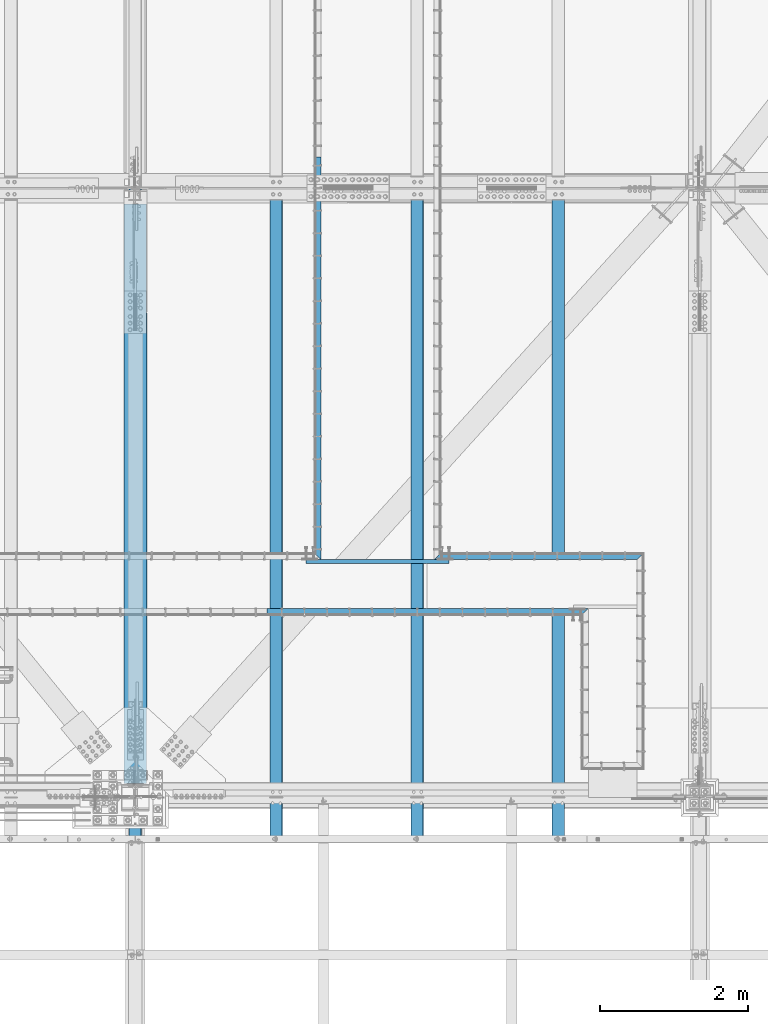
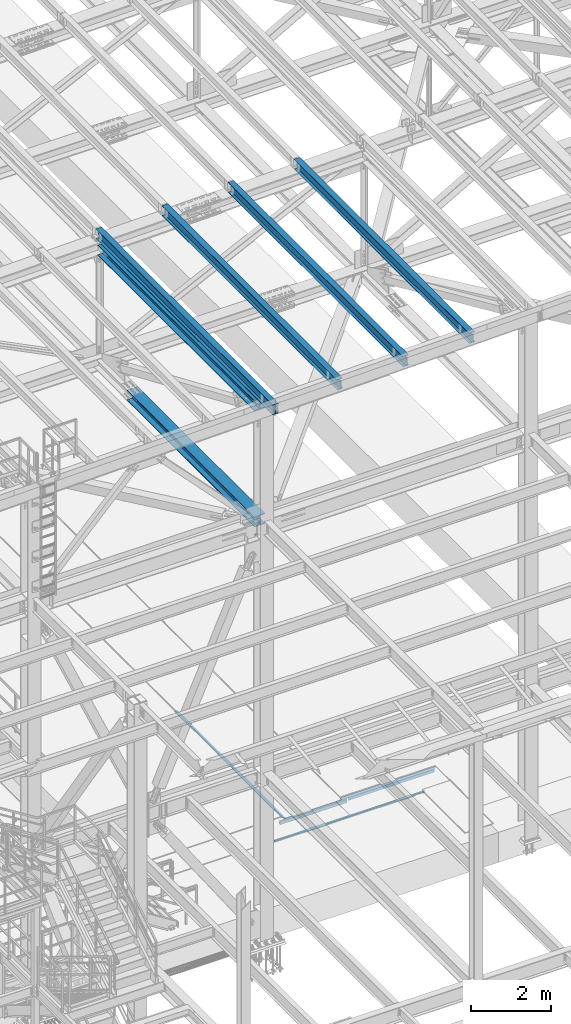
# One storey, part 1799 of 3843: 10 beams, 10 elements without a shape of their own.
"""IFC2X3 building model written with IfcOpenShell, lengths in millimetres."""

from ifc_helpers import new_model, si_unit, frame, origin_with_axes, place, context, subcontext, project, spatial, faceted_brep, material, type_object, element, aggregate, save


model = new_model("IFC2X3")

# Units and contexts
model_context = context("Model", 3, precision=1e-05, world=origin_with_axes())
body_context = subcontext(model_context, "Body", "Model", "MODEL_VIEW")
ifc_project = project(units=[si_unit("LENGTHUNIT", "METRE", prefix="MILLI"), si_unit("AREAUNIT", "SQUARE_METRE"), si_unit("VOLUMEUNIT", "CUBIC_METRE"), si_unit("MASSUNIT", "GRAM", prefix="KILO"), si_unit("TIMEUNIT", "SECOND"), si_unit("PLANEANGLEUNIT", "RADIAN"), si_unit("SOLIDANGLEUNIT", "STERADIAN"), si_unit("THERMODYNAMICTEMPERATUREUNIT", "DEGREE_CELSIUS"), si_unit("LUMINOUSINTENSITYUNIT", "LUMEN")], contexts=[model_context])

# Site, building, storey
site_placement = place(None, origin_with_axes())
site = spatial("IfcSite", under=ifc_project, at=site_placement, CompositionType="ELEMENT")
building_placement = place(site_placement, origin_with_axes())
building = spatial("IfcBuilding", under=site, at=building_placement, Name="Undefined", CompositionType="ELEMENT")
storey_placement = place(building_placement, origin_with_axes())
storey = spatial("IfcBuildingStorey", under=building, at=storey_placement, Name="Undefined", CompositionType="ELEMENT", Elevation=0.0)

# Assembly, beam
assembly_1_placement = place(storey_placement, origin_with_axes())
assembly_1 = element("IfcElementAssembly", 1, at=assembly_1_placement, inside=storey, Name="EMBED_ANGLE", AssemblyPlace="NOTDEFINED", PredefinedType="RIGID_FRAME")
ifc_material_1 = material(Name="STEEL/A36")
beam_type_1 = type_object("IfcBeamType", Name="L3-1/2X3-1/2X5/16", PredefinedType="NOTDEFINED")
beam_1_placement = place(assembly_1_placement, frame((66669.4119999985, 28873.45, 30410.15), z_axis=(0.0, 0.0, -1.0), x_axis=(1.0, 0.0, 0.0)))
beam_1 = element("IfcBeam", 2, at=beam_1_placement, type_object=beam_type_1, material=ifc_material_1, Name="EMBED_ANGLE", ObjectType="L3-1/2X3-1/2X5/16", context=body_context, shape_type="Brep", body=[
    faceted_brep([(44.4500000014959, 36.5125000000007, 44.4500000000007), (44.4499983150599, 36.5125000000007, -36.5125000001281), (44.4500000014959, 44.4500000000007, -36.5124999999935), (44.4500000014959, 44.4500000000007, 44.4500000000007), (260.349998315098, 36.5125000000007, -36.5125000007247), (260.350000001519, 44.4500000000007, -36.5124999999971), (260.349981232008, 36.5125000000007, 44.4499999992695), (260.350000001519, 44.4500000000007, 44.4500000000007), (2751.13746728744, 36.5125000000007, -36.5125000076368), (2751.13745121389, 36.5125000000007, 44.4500000000007), (260.349998315098, -44.4499999999971, -36.5125000007247), (88.9000039503298, -44.4500000001644, -36.5125000000007), (88.8999999971129, -44.4500000000007, -44.4499999999971), (2832.09995201537, -44.4500000000007, -44.4500000000007), (2832.09995201537, -44.4500000000007, -36.5125000000007), (44.4500000014959, 1.81898940354586e-11, -36.5125000000007), (7.93749960740388, 36.5125000000007, -36.5124999999825), (7.93750032749085, 36.5124999999825, 44.4500000000007), (-3.63797880709171e-12, 44.4499999999971, 44.4500000000007), (-3.63797880709171e-12, 44.4499999999971, -44.4500000000007), (2743.19996850427, 44.4500000000007, -44.4500000076223), (2743.19995113531, 44.4500000000007, 44.4500000000007)], [[[0, 1, 2, 3]], [[4, 5, 2, 1]], [[6, 7, 5, 4]], [[8, 9, 6, 4]], [[10, 11, 12, 13, 14]], [[12, 11, 15, 16, 17, 18, 19]], [[12, 19, 20, 13]], [[9, 8, 14, 13, 20, 21]], [[4, 1, 16, 15, 11, 10, 14, 8]], [[17, 16, 1, 0]], [[18, 17, 0, 3]], [[21, 20, 19, 18, 3, 2, 5, 7]], [[9, 21, 7, 6]]]),
])
aggregate(assembly_1, [beam_1])

assembly_2_placement = place(storey_placement, origin_with_axes())
assembly_2 = element("IfcElementAssembly", 3, at=assembly_2_placement, inside=storey, Name="EMBED_ANGLE", AssemblyPlace="NOTDEFINED", PredefinedType="RIGID_FRAME")
beam_2_placement = place(assembly_2_placement, frame((64415.1623417764, 28124.15, 30410.15), z_axis=(0.0, -1.0, 0.0), x_axis=(1.0, 0.0, 0.0)))
beam_2 = element("IfcBeam", 4, at=beam_2_placement, type_object=beam_type_1, material=ifc_material_1, Name="EMBED_ANGLE", ObjectType="L3-1/2X3-1/2X5/16", context=body_context, shape_type="Brep", body=[
    faceted_brep([(4076.69926759853, -44.4500000000007, -36.5125000000007), (4076.69926759853, -44.4500000000007, -44.4500000000007), (4076.69926759853, 36.5125000000007, -44.4500000000007), (4076.69926759853, 36.5125000000007, -36.5125000000007), (4292.59926759854, 36.5125000000007, -44.4500000000007), (4292.59926759854, 36.5125000000007, -36.5125000000007), (4292.59926759854, -44.4500000000007, -36.5125000000007), (4292.59926759854, -44.4500000000007, -44.4500000000007), (4337.04946592326, -44.4500000000007, -44.4500000000007), (4329.11196648452, -44.4500000000007, -36.5125000000007), (3.63797880709171e-12, -44.4499999999971, -44.4500000000007), (-3.63797880709171e-12, 44.4499999999971, -44.4500000000007), (4337.04946592326, 44.4500000000007, -44.4500000000007), (3.63797880709171e-12, -44.4499999999971, -36.5125000000007), (-3.63797880709171e-12, 36.5124999999971, -36.5125000000007), (-3.63797880709171e-12, 36.5124999999971, 44.4500000000007), (-3.63797880709171e-12, 44.4499999999971, 44.4500000000007), (4076.69926759853, 36.5125000000007, 44.4500000000007), (4248.14947220943, 36.5125000000007, 44.4500000000007), (4248.14947220943, 44.4500000000007, 44.4500000000007), (4292.59926759854, 36.5125000000007, 0.000201467813894851), (4329.11196648452, 36.5125000000007, -36.5125000000007)], [[[0, 1, 2, 3]], [[3, 2, 4, 5]], [[6, 5, 4, 7]], [[8, 9, 6, 7]], [[2, 1, 10, 11, 12, 8, 7, 4]], [[13, 10, 1, 0]], [[14, 13, 0, 3]], [[10, 13, 14, 15, 16, 11]], [[16, 15, 17, 18, 19]], [[11, 16, 19, 12]], [[18, 20, 21, 9, 8, 12, 19]], [[17, 15, 14, 3, 5, 21, 20, 18]], [[9, 21, 5, 6]]]),
])
aggregate(assembly_2, [beam_2])

assembly_3_placement = place(storey_placement, origin_with_axes())
assembly_3 = element("IfcElementAssembly", 5, at=assembly_3_placement, inside=storey, Name="EMBED_ANGLE", AssemblyPlace="NOTDEFINED", PredefinedType="RIGID_FRAME")
beam_3_placement = place(assembly_3_placement, frame((65101.0255556641, 28829.0, 30410.15), z_axis=(0.0, 0.0, -1.0), x_axis=(0.0, 1.0, 0.0)))
beam_3 = element("IfcBeam", 6, at=beam_3_placement, type_object=beam_type_1, material=ifc_material_1, Name="EMBED_ANGLE", ObjectType="L3-1/2X3-1/2X5/16", context=body_context, shape_type="Brep", body=[
    faceted_brep([(-3.63797880709171e-12, 44.4499999999971, -44.4500000000007), (-3.63797880709171e-12, 44.4499999999971, 44.4500000000007), (5435.6001953125, 44.4499999999971, 44.4500000000007), (5435.6001953125, 44.4499999999971, -44.4500000000007), (7.93750032749085, 36.5124999999825, 44.4500000000007), (5435.60019531249, 36.5124999999971, 44.4500000000007), (7.93749960740388, 36.5125000000007, -36.5124999999825), (5435.60019531249, 36.5124999999971, -36.5125000000007), (88.9000039503298, -44.4500000001644, -36.5125000000007), (5435.60019531249, -44.4499999999971, -36.5125000000007), (88.8999999971129, -44.4500000000007, -44.4499999999971), (5435.60019531249, -44.4499999999971, -44.4500000000007)], [[[0, 1, 2, 3]], [[1, 4, 5, 2]], [[4, 6, 7, 5]], [[6, 8, 9, 7]], [[8, 10, 11, 9]], [[10, 0, 3, 11]], [[5, 7, 9, 11, 3, 2]], [[10, 8, 6, 4, 1, 0]]]),
])
aggregate(assembly_3, [beam_3])

assembly_4_placement = place(storey_placement, origin_with_axes())
assembly_4 = element("IfcElementAssembly", 7, at=assembly_4_placement, inside=storey, Name="BEAM", AssemblyPlace="NOTDEFINED", PredefinedType="RIGID_FRAME")
ifc_material_2 = material(Name="STEEL/A992")
beam_type_2 = type_object("IfcBeamType", Name="W12X26", PredefinedType="NOTDEFINED")
beam_4_placement = place(assembly_4_placement, frame((62633.1092622695, 25006.0787452875, 46125.2705282097), z_axis=(-0.0211520984080489, -0.00142217399974833, 0.999775257822502), x_axis=(0.0, 0.999998988257743, 0.00142249200036651)))
beam_4 = element("IfcBeam", 8, at=beam_4_placement, type_object=beam_type_2, material=ifc_material_2, Name="BEAM", ObjectType="W12X26", context=body_context, shape_type="Brep", body=[
    faceted_brep([(0.0, 82.5500000000029, -155.574999999997), (0.0, 82.5500000000029, -146.050000000003), (8826.51999255239, 82.5500000000393, -146.049999990893), (8826.50644633373, 82.5500000000684, -155.574999990939), (0.0, 3.17500000000291, -146.050000000003), (8826.52238084464, 3.17500000018481, -146.049999990959), (0.0, 3.17500000000291, 146.050000000003), (8826.93779821671, 3.17499999938445, 146.050000009942), (0.0, 82.5500000000029, 146.050000000003), (8826.93540992444, 82.5499999992389, 146.050000009986), (0.0, 82.5500000000029, 155.574999999997), (8826.9489561431, 82.5499999992171, 155.575000010031), (0.0, -82.5500000000029, 155.574999999997), (8826.95392379099, -82.5500000004686, 155.5750000099), (0.0, -82.5500000000029, 146.050000000003), (8826.94037757234, -82.5500000004467, 146.050000009876), (0.0, -3.17500000000291, 146.050000000003), (8826.93798928008, -3.17500000059226, 146.050000009927), (0.0, -3.17500000000291, -146.050000000003), (8826.52257190803, -3.17499999979918, -146.049999990966), (0.0, -82.5500000000029, -146.050000000003), (8826.52496020028, -82.5499999996537, -146.049999991017), (0.0, -82.5500000000029, -155.574999999997), (8826.51141398162, -82.5499999996318, -155.574999991055)], [[[0, 1, 2, 3]], [[1, 4, 5, 2]], [[4, 6, 7, 5]], [[6, 8, 9, 7]], [[8, 10, 11, 9]], [[10, 12, 13, 11]], [[12, 14, 15, 13]], [[14, 16, 17, 15]], [[16, 18, 19, 17]], [[18, 20, 21, 19]], [[20, 22, 23, 21]], [[22, 0, 3, 23]], [[5, 7, 9, 11, 13, 15, 17, 19, 21, 23, 3, 2]], [[22, 20, 18, 16, 14, 12, 10, 8, 6, 4, 1, 0]]]),
])
aggregate(assembly_4, [beam_4])

assembly_5_placement = place(storey_placement, origin_with_axes())
assembly_5 = element("IfcElementAssembly", 9, at=assembly_5_placement, inside=storey, Name="BEAM", AssemblyPlace="NOTDEFINED", PredefinedType="RIGID_FRAME")
beam_5_placement = place(assembly_5_placement, frame((68348.1092622725, 25006.0302246526, 46246.1817432963), z_axis=(-0.0211520978230692, -0.00173405299920705, 0.99977476554366), x_axis=(0.0, 0.999998495856078, 0.00173444099975001)))
beam_5 = element("IfcBeam", 10, at=beam_5_placement, type_object=beam_type_2, material=ifc_material_2, Name="BEAM", ObjectType="W12X26", context=body_context, shape_type="Brep", body=[
    faceted_brep([(20.6816926623724, -3.17500000046857, -130.174999976822), (20.6814596991535, 3.17499999956635, -130.174999976844), (77.784502840419, 3.17499999956635, -130.174999976844), (77.7845028404154, -3.17500000048312, -130.174999976851), (82.6445823584691, 3.1749999995518, -131.141729899435), (82.6445823584618, -3.17500000048312, -131.141729899435), (86.7647588266263, 3.17499999953725, -133.89474379993), (86.7647588266191, -3.17500000048312, -133.894743799938), (89.517772727093, 3.1749999995227, -138.014920268128), (89.5177727270966, -3.17500000051223, -138.014920268135), (90.4845026496732, -3.17500000052678, -142.874999786232), (90.4845026496769, 3.17499999950815, -142.874999786225), (90.4845026497314, 3.17499999949359, -146.050000000396), (90.4845026497314, 82.5499999999156, -146.050000000505), (90.4845026497314, 82.549999999901, -155.575000000536), (90.4845026497278, -82.5500000009924, -155.575000000303), (90.4845026497278, -82.5500000009633, -146.050000000272), (90.4845026497278, -3.17500000054133, -146.050000000389), (8827.0393394318, -82.5500000001339, 146.050000009294), (8827.05585631101, -82.5500000000902, 155.575000009325), (90.4845026501171, -82.5499999999302, 155.442603666794), (90.4845026501207, -82.5499999999447, 146.050000000687), (8827.04979926735, 82.5500000007742, 155.575000009099), (90.4845026501207, 82.5500000009488, 155.575000000477), (8827.03328238814, 82.5500000007451, 146.050000009061), (90.4845026501171, 82.5500000009197, 146.050000000447), (8827.03619442835, 3.17500000032305, 146.050000009178), (90.4845026501171, 3.17500000051223, 146.050000000563), (77.7845028407501, -3.17499999959546, 130.175000025702), (77.7845028407573, 3.17500000045402, 130.175000025702), (21.1329210645781, 3.17500000045402, 130.175000026), (21.1331540277934, -3.17499999959546, 130.175000026029), (82.6445823587856, -3.1749999995809, 131.141729948307), (82.6445823587892, 3.17500000045402, 131.141729948315), (86.7647588269356, -3.1749999995809, 133.894743848818), (86.7647588269356, 3.17500000045402, 133.894743848825), (89.5177727274131, -3.17499999956635, 138.014920317015), (89.5177727274167, 3.17500000046857, 138.014920317015), (90.4845026500079, -3.1749999995518, 142.874999835105), (90.4845026500152, 3.17500000049768, 142.874999835105), (90.4845026501207, -3.17499999953725, 146.050000000578), (8827.03642739157, -3.17499999971187, 146.050000009178), (8826.52967679886, 3.17499999931897, -146.049999991781), (8826.52990976208, -3.17500000071595, -146.049999991774), (8826.5328218023, -82.550000001138, -146.049999991665), (8826.51630492308, -82.5500000011671, -155.574999991695), (8826.51024787942, 82.5499999997264, -155.574999991928), (8826.52676475865, 82.549999999741, -146.049999991897), (20.7111213191383, 3.17499999962456, -113.069654194216), (21.1109939304115, 3.17500000041036, 117.52999910916)], [[[0, 1, 2, 3]], [[3, 2, 4, 5]], [[5, 4, 6, 7]], [[7, 6, 8, 9]], [[10, 11, 12, 13, 14, 15, 16, 17]], [[9, 8, 11, 10]], [[18, 19, 20, 21]], [[19, 22, 23, 20]], [[22, 24, 25, 23]], [[24, 26, 27, 25]], [[28, 29, 30, 31]], [[32, 33, 29, 28]], [[34, 35, 33, 32]], [[36, 37, 35, 34]], [[38, 39, 37, 36]], [[20, 23, 25, 27, 39, 38, 40, 21]], [[41, 18, 21, 40]], [[42, 26, 24, 22, 19, 18, 41, 43, 44, 45, 46, 47]], [[44, 43, 17, 16]], [[45, 44, 16, 15]], [[46, 45, 15, 14]], [[47, 46, 14, 13]], [[42, 47, 13, 12]], [[6, 4, 2, 1, 48, 49, 30, 29, 33, 35, 37, 39, 27, 26, 42, 12, 11, 8]], [[31, 30, 49, 48, 1, 0]], [[43, 41, 40, 38, 36, 34, 32, 28, 31, 0, 3, 5, 7, 9, 10, 17]]]),
])
aggregate(assembly_5, [beam_5])

assembly_6_placement = place(storey_placement, origin_with_axes())
assembly_6 = element("IfcElementAssembly", 11, at=assembly_6_placement, inside=storey, Name="BEAM", AssemblyPlace="NOTDEFINED", PredefinedType="RIGID_FRAME")
beam_6_placement = place(assembly_6_placement, frame((66443.1092622736, 25006.0463981901, 46205.8780066179), z_axis=(-0.0211520981232898, -0.00163009300072372, 0.999774940444994), x_axis=(0.0, 0.999998670802472, 0.00163045799967754)))
beam_6 = element("IfcBeam", 12, at=beam_6_placement, type_object=beam_type_2, material=ifc_material_2, Name="BEAM", ObjectType="W12X26", context=body_context, shape_type="Brep", body=[
    faceted_brep([(20.6790414785355, -3.17499999985739, -130.175000004718), (20.6788224819284, 3.17500000017753, -130.175000004718), (77.784680792578, 3.17500000019209, -130.175000004507), (77.7846807925889, -3.17499999985739, -130.175000004507), (82.6447603106244, 3.17500000017753, -131.141729927098), (82.644760310639, -3.17499999985739, -131.141729927098), (86.7649367787781, 3.17500000019209, -133.894743827615), (86.7649367787963, -3.17499999984284, -133.894743827608), (89.5179506792483, 3.17500000019209, -138.014920295805), (89.5179506792629, -3.17499999984284, -138.014920295798), (90.4846806018431, -3.17499999984284, -142.874999813896), (90.4846806018286, 3.17500000019209, -142.87499981391), (90.4846806016067, 3.17500000020664, -146.050000000549), (90.484680601603, 82.5500000006577, -146.050000000534), (90.4846806015921, 82.5500000006577, -155.575000000565), (90.4846806015958, -82.5500000002794, -155.575000000601), (90.4846806016067, -82.5500000002794, -146.05000000057), (90.4846806016067, -3.17499999984284, -146.050000000549), (8827.00625671329, -82.5500000004249, 146.04999999042), (8827.02178337182, -82.5500000004395, 155.574999990458), (90.4846806021815, -82.5500000006432, 155.450567705419), (90.4846806021706, -82.5500000006432, 146.050000000323), (8827.01608946006, 82.5500000004977, 155.574999990495), (90.4846806021742, 82.5500000002794, 155.575000000397), (8827.00056280154, 82.5500000005122, 146.049999990471), (90.4846806021669, 82.5500000003085, 146.050000000367), (8827.00330025912, 3.17500000006112, 146.04999999045), (90.4846806021669, 3.17499999984284, 146.050000000345), (77.7846807930873, -3.17500000014843, 130.174999997886), (77.7846807930691, 3.17499999987194, 130.174999997878), (21.1032178149762, 3.17499999984284, 130.174999997776), (21.1034368115797, -3.17500000017753, 130.174999997769), (82.6447603111337, -3.17500000017753, 131.141729920477), (82.6447603111192, 3.17499999987194, 131.141729920477), (86.764936779291, -3.17500000017753, 133.89474382098), (86.7649367792765, 3.17499999984284, 133.894743820973), (89.5179506797795, -3.17500000017753, 138.014920289163), (89.5179506797613, 3.17499999987194, 138.014920289155), (90.4846806023779, -3.17500000019209, 142.874999807253), (90.4846806023597, 3.17499999984284, 142.874999807253), (90.4846806021669, -3.17500000017753, 146.050000000345), (8827.00351925572, -3.17499999997381, 146.04999999045), (8826.52714939765, 3.17500000041036, -146.050000010451), (8826.52736839425, -3.17499999962456, -146.050000010458), (8826.53010585183, -82.5500000000757, -146.050000010466), (8826.5145791933, -82.5500000000611, -155.575000010504), (8826.50888528155, 82.550000000876, -155.57500001046), (8826.52441194007, 82.5500000008615, -146.050000010429), (20.7067003917982, 3.17500000014843, -113.072988577936), (21.0825998877735, 3.17499999987194, 117.526705049044)], [[[0, 1, 2, 3]], [[3, 2, 4, 5]], [[5, 4, 6, 7]], [[7, 6, 8, 9]], [[10, 11, 12, 13, 14, 15, 16, 17]], [[9, 8, 11, 10]], [[18, 19, 20, 21]], [[19, 22, 23, 20]], [[22, 24, 25, 23]], [[24, 26, 27, 25]], [[28, 29, 30, 31]], [[32, 33, 29, 28]], [[34, 35, 33, 32]], [[36, 37, 35, 34]], [[38, 39, 37, 36]], [[20, 23, 25, 27, 39, 38, 40, 21]], [[41, 18, 21, 40]], [[42, 26, 24, 22, 19, 18, 41, 43, 44, 45, 46, 47]], [[44, 43, 17, 16]], [[45, 44, 16, 15]], [[46, 45, 15, 14]], [[47, 46, 14, 13]], [[42, 47, 13, 12]], [[6, 4, 2, 1, 48, 49, 30, 29, 33, 35, 37, 39, 27, 26, 42, 12, 11, 8]], [[31, 30, 49, 48, 1, 0]], [[43, 41, 40, 38, 36, 34, 32, 28, 31, 0, 3, 5, 7, 9, 10, 17]]]),
])
aggregate(assembly_6, [beam_6])

assembly_7_placement = place(storey_placement, origin_with_axes())
assembly_7 = element("IfcElementAssembly", 13, at=assembly_7_placement, inside=storey, Name="BEAM", AssemblyPlace="NOTDEFINED", PredefinedType="RIGID_FRAME")
beam_7_placement = place(assembly_7_placement, frame((64538.1092622714, 25006.0625717364, 46165.5742682565), z_axis=(-0.0211520976508328, -0.00152613299931545, 0.999775104552538), x_axis=(0.0, 0.999998834936359, 0.00152647499990309)))
beam_7 = element("IfcBeam", 14, at=beam_7_placement, type_object=beam_type_2, material=ifc_material_2, Name="BEAM", ObjectType="W12X26", context=body_context, shape_type="Brep", body=[
    faceted_brep([(20.676390512941, -3.17500000043947, -130.1749999858), (20.6761854829601, 3.17499999953725, -130.174999985822), (77.7848589575078, 3.17499999954453, -130.17499998695), (77.7848589574933, -3.17500000043947, -130.174999986928), (82.6449384755688, 3.17499999954453, -131.141729909577), (82.6449384755579, -3.17500000043947, -131.141729909556), (86.7651149437406, 3.17499999953725, -133.894743810088), (86.7651149437334, -3.17500000044674, -133.894743810066), (89.5181288442473, 3.17499999951542, -138.014920278256), (89.5181288442327, -3.17500000046857, -138.014920278241), (90.4848587668457, -3.17500000047585, -142.874999796295), (90.4848587668603, 3.17499999950087, -142.874999796317), (90.4848587670203, 3.17499999948632, -146.050000000374), (90.4848587670131, 82.5499999993335, -146.050000000636), (90.484858766984, 82.5499999993117, -155.575000000637), (90.4848587669949, -82.550000000374, -155.575000000092), (90.484858767024, -82.5500000003449, -146.05000000009), (90.4848587670203, -3.1750000004904, -146.050000000359), (8826.9732694464, -82.549999998686, 146.049999968978), (8826.9878058847, -82.5499999986714, 155.574999968972), (90.4848587698471, -82.5499999993699, 155.458528436873), (90.4848587698543, -82.5499999993554, 146.049999999988), (8826.98247510529, 82.5500000010215, 155.574999968434), (90.4848587698361, 82.5500000003667, 155.574999999451), (8826.96793866699, 82.5500000009852, 146.049999968433), (90.4848587698398, 82.5500000003231, 146.049999999443), (8826.97050154171, 3.17500000113796, 146.049999968694), (90.4848587698434, 3.17500000047585, 146.049999999705), (77.7848589606147, -3.17499999955908, 130.175000013041), (77.7848589606256, 3.17500000043219, 130.175000013027), (21.0735147965243, 3.17500000042492, 130.175000013034), (21.0737198265051, -3.17499999956635, 130.175000013056), (82.6449384786793, -3.17499999955908, 131.141729935604), (82.6449384786974, 3.17500000042492, 131.141729935582), (86.7651149468438, -3.1749999995518, 133.89474383607), (86.7651149468547, 3.17500000044674, 133.894743836041), (89.5181288473068, -3.17499999953725, 138.014920304217), (89.5181288473177, 3.17500000044674, 138.014920304195), (90.4848587698616, -3.17499999951542, 142.874999822277), (90.4848587698798, 3.17500000046857, 142.874999822256), (90.4848587698471, -3.17499999950087, 146.049999999726), (8826.97070657169, -3.17499999884603, 146.049999968709), (8826.52471743381, 3.17500000014843, -146.050000031384), (8826.52492246379, -3.17499999982829, -146.05000003137), (8826.52748533851, -82.5499999996755, -146.050000031108), (8826.51294890021, -82.5499999997191, -155.575000031109), (8826.50761812079, 82.5499999999665, -155.575000031655), (8826.52215455908, 82.5499999999956, -146.050000031646), (20.7022803798318, 3.17499999960273, -113.07632096186), (21.0542067597344, 3.17500000037398, 117.523410495785)], [[[0, 1, 2, 3]], [[3, 2, 4, 5]], [[5, 4, 6, 7]], [[7, 6, 8, 9]], [[10, 11, 12, 13, 14, 15, 16, 17]], [[9, 8, 11, 10]], [[18, 19, 20, 21]], [[19, 22, 23, 20]], [[22, 24, 25, 23]], [[24, 26, 27, 25]], [[28, 29, 30, 31]], [[32, 33, 29, 28]], [[34, 35, 33, 32]], [[36, 37, 35, 34]], [[38, 39, 37, 36]], [[20, 23, 25, 27, 39, 38, 40, 21]], [[41, 18, 21, 40]], [[42, 26, 24, 22, 19, 18, 41, 43, 44, 45, 46, 47]], [[44, 43, 17, 16]], [[45, 44, 16, 15]], [[46, 45, 15, 14]], [[47, 46, 14, 13]], [[42, 47, 13, 12]], [[6, 4, 2, 1, 48, 49, 30, 29, 33, 35, 37, 39, 27, 26, 42, 12, 11, 8]], [[31, 30, 49, 48, 1, 0]], [[43, 41, 40, 38, 36, 34, 32, 28, 31, 0, 3, 5, 7, 9, 10, 17]]]),
])
aggregate(assembly_7, [beam_7])

assembly_8_placement = place(storey_placement, origin_with_axes())
assembly_8 = element("IfcElementAssembly", 15, at=assembly_8_placement, inside=storey, Name="BEAM", AssemblyPlace="NOTDEFINED", PredefinedType="RIGID_FRAME")
beam_type_3 = type_object("IfcBeamType", Name="W12X79", PredefinedType="NOTDEFINED")
beam_8_placement = place(assembly_8_placement, frame((62636.4000000252, 25615.8999999988, 42246.55), z_axis=(0.0, -0.00152891300032206, 0.999998831211836), x_axis=(0.0, 0.999998831211836, 0.00152891300031876)))
beam_8 = element("IfcBeam", 16, at=beam_8_placement, type_object=beam_type_3, material=ifc_material_2, Name="BEAM", ObjectType="W12X79", context=body_context, shape_type="Brep", body=[
    faceted_brep([(190.740510718948, -153.987500000003, -138.112499999617), (190.740510718875, -153.987500000003, -157.162499999627), (6546.85765931154, -153.987500000003, -157.162499986407), (6546.85765931161, -153.987500000003, -138.112499986411), (190.740510718948, -6.34999999999854, -138.112499999617), (6546.85765931161, -6.34999999999854, -138.112499986411), (190.740510719945, -6.34999999999854, 138.112500000418), (6546.85765931261, -6.34999999999854, 138.112500013631), (190.740510719945, -153.987500000003, 138.112500000418), (6546.85765931261, -153.987500000003, 138.112500013631), (190.740510720014, -153.987500000003, 157.162500000428), (6546.85765931269, -153.987500000003, 157.162500013634), (190.740510720014, 153.987500000003, 157.162500000428), (6546.85765931269, 153.987500000003, 157.162500013634), (190.740510719945, 153.987500000003, 138.112500000418), (6546.85765931261, 153.987500000003, 138.112500013631), (190.740510719945, 6.34999999999854, 138.112500000418), (6546.85765931261, 6.34999999999854, 138.112500013631), (190.740510718948, 6.34999999999854, -138.112499999617), (6546.85765931161, 6.34999999999854, -138.112499986411), (190.740510718948, 153.987500000003, -138.112499999617), (6546.85765931161, 153.987500000003, -138.112499986411), (190.740510718875, 153.987500000003, -157.162499999627), (6546.85765931154, 153.987500000003, -157.162499986407)], [[[0, 1, 2, 3]], [[4, 0, 3, 5]], [[6, 4, 5, 7]], [[8, 6, 7, 9]], [[10, 8, 9, 11]], [[12, 10, 11, 13]], [[14, 12, 13, 15]], [[16, 14, 15, 17]], [[18, 16, 17, 19]], [[20, 18, 19, 21]], [[1, 0, 4, 6, 8, 10, 12, 14, 16, 18, 20, 22]], [[1, 22, 23, 2]], [[19, 17, 15, 13, 11, 9, 7, 5, 3, 2, 23, 21]], [[22, 20, 21, 23]]]),
])
aggregate(assembly_8, [beam_8])

assembly_9_placement = place(storey_placement, origin_with_axes())
assembly_9 = element("IfcElementAssembly", 17, at=assembly_9_placement, inside=storey, Name="BEAM", AssemblyPlace="NOTDEFINED", PredefinedType="RIGID_FRAME")
beam_type_4 = type_object("IfcBeamType", Name="W12X65", PredefinedType="NOTDEFINED")
beam_9_placement = place(assembly_9_placement, frame((62636.4, 25615.9, 45785.4081121488), z_axis=(0.0, 0.0, 1.0), x_axis=(0.0, 1.0, 0.0)))
beam_9 = element("IfcBeam", 18, at=beam_9_placement, type_object=beam_type_4, material=ifc_material_2, Name="BEAM", ObjectType="W12X65", context=body_context, shape_type="Brep", body=[
    faceted_brep([(190.499999998636, -152.399999999994, -138.112500000003), (190.499999998636, -152.399999999994, -153.987500000003), (8016.87499999944, -152.399999999994, -153.987500000003), (8016.87499999944, -152.399999999994, -138.112500000003), (190.499999998636, -4.76249999999709, -138.112500000003), (8016.87499999944, -4.76249999999709, -138.112500000003), (190.499999998636, -4.76249999999709, 138.112500000003), (8016.87499999944, -4.76249999999709, 138.112500000003), (190.499999998636, -152.399999999994, 138.112500000003), (8016.87499999944, -152.399999999994, 138.112500000003), (190.499999998636, -152.399999999994, 153.987500000003), (8016.87499999944, -152.399999999994, 153.987500000003), (190.499999998636, 152.399999999994, 153.987500000003), (8016.87499999944, 152.399999999994, 153.987500000003), (190.499999998636, 152.399999999994, 138.112500000003), (8016.87499999944, 152.399999999994, 138.112500000003), (190.499999998636, 4.76249999999709, 138.112500000003), (8016.87499999944, 4.76249999999709, 138.112500000003), (190.499999998636, 4.76249999999709, -138.112500000003), (8016.87499999944, 4.76249999999709, -138.112500000003), (190.499999998636, 152.399999999994, -138.112500000003), (8016.87499999944, 152.399999999994, -138.112500000003), (190.499999998636, 152.399999999994, -153.987500000003), (8016.87499999944, 152.399999999994, -153.987500000003)], [[[0, 1, 2, 3]], [[4, 0, 3, 5]], [[6, 4, 5, 7]], [[8, 6, 7, 9]], [[10, 8, 9, 11]], [[12, 10, 11, 13]], [[14, 12, 13, 15]], [[16, 14, 15, 17]], [[18, 16, 17, 19]], [[20, 18, 19, 21]], [[1, 0, 4, 6, 8, 10, 12, 14, 16, 18, 20, 22]], [[1, 22, 23, 2]], [[19, 17, 15, 13, 11, 9, 7, 5, 3, 2, 23, 21]], [[22, 20, 21, 23]]]),
])
aggregate(assembly_9, [beam_9])

assembly_10_placement = place(storey_placement, origin_with_axes())
assembly_10 = element("IfcElementAssembly", 19, at=assembly_10_placement, inside=storey, Name="COVER PLATE", AssemblyPlace="NOTDEFINED", PredefinedType="RIGID_FRAME")
beam_type_5 = type_object("IfcBeamType", PredefinedType="NOTDEFINED")
beam_10_placement = place(assembly_10_placement, frame((64942.2120976562, 28803.6, 30403.8), z_axis=(0.0, 0.0, 1.0), x_axis=(1.0, 0.0, 0.0)))
beam_10 = element("IfcBeam", 20, at=beam_10_placement, type_object=beam_type_5, material=ifc_material_1, Name="COVER PLATE", context=body_context, shape_type="Brep", body=[
    faceted_brep([(6.54836185276508e-11, 25.4000000000087, -50.7999999999993), (6.54836185276508e-11, 25.4000000000087, 50.7999999999993), (1930.40032324089, 25.4000000105443, 50.7999999999993), (1930.40032324089, 25.4000000105443, -50.7999999999993), (-2.91038304567337e-11, -25.3999999999942, 50.7999999999993), (1930.40032324079, -25.3999999894731, 50.7999999999993), (-2.91038304567337e-11, -25.3999999999942, -50.7999999999993), (1930.40032324079, -25.3999999894731, -50.7999999999993)], [[[0, 1, 2, 3]], [[1, 4, 5, 2]], [[4, 6, 7, 5]], [[6, 0, 3, 7]], [[5, 7, 3, 2]], [[6, 4, 1, 0]]]),
])
aggregate(assembly_10, [beam_10])

save(model, "model.ifc")
